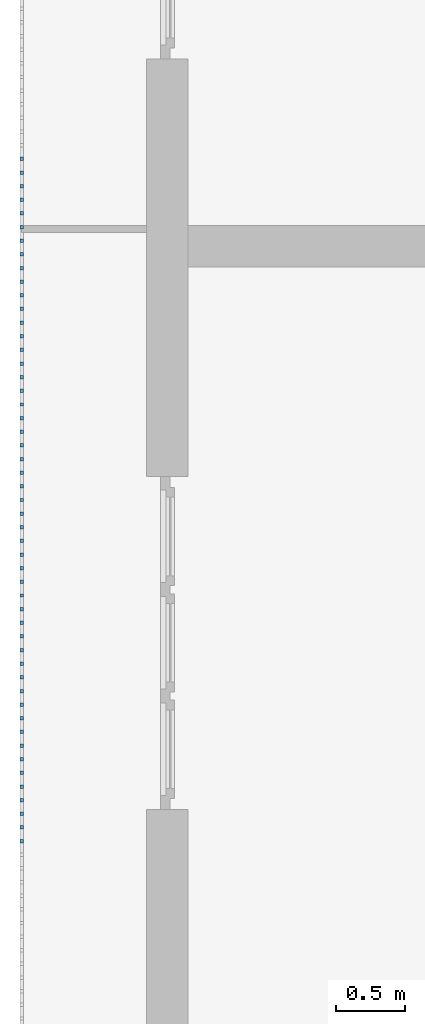
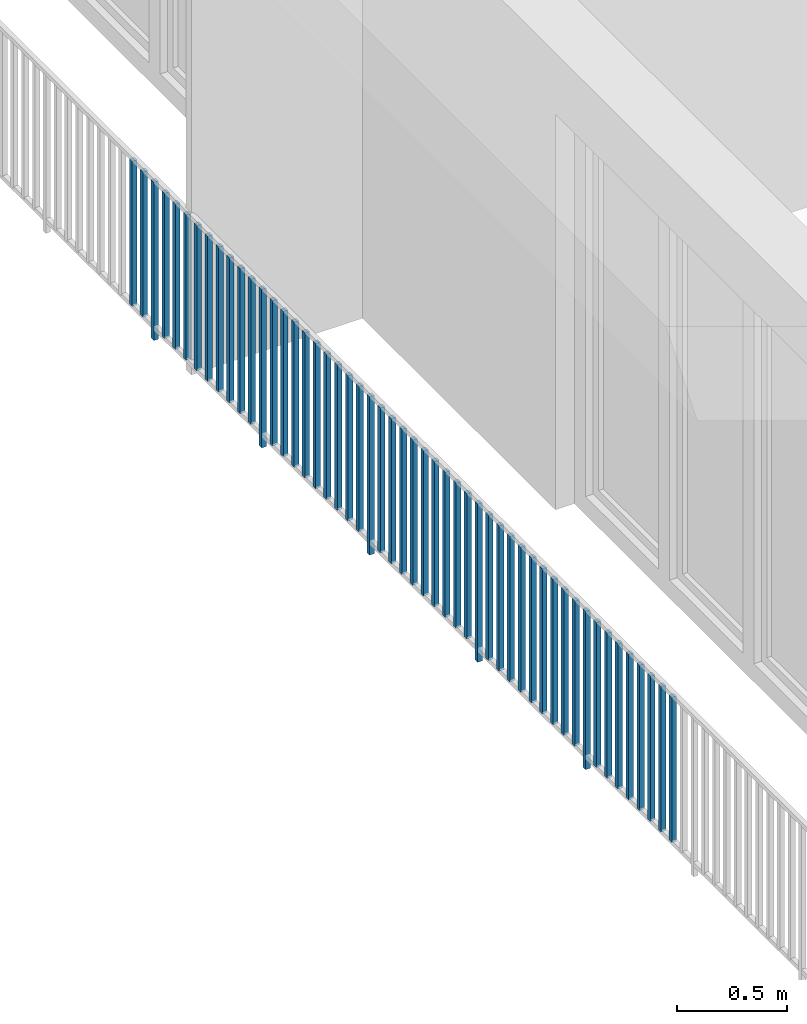
# One storey, part 31 of 48: 51 building element parts, 1 element without a shape of its own.
"""IFC4 building model written with IfcOpenShell, lengths in metres."""

from ifc_helpers import new_model, entity, si_unit, converted_unit, derived_unit, direction, frame, origin_with_axes, place, context, subcontext, project, spatial, polygons, material, type_object, element, aggregate, save


model = new_model("IFC4")

# Units and contexts
model_context = context("Model", 3, precision=1e-05, world=origin_with_axes(), true_north=direction((0.0, 1.0)))
body_context = subcontext(model_context, "Body", "Model", "MODEL_VIEW")
ifc_project = project(units=[si_unit("LENGTHUNIT", "METRE"), si_unit("AREAUNIT", "SQUARE_METRE"), si_unit("VOLUMEUNIT", "CUBIC_METRE"), converted_unit("PLANEANGLEUNIT", "DEGREE", entity("IfcPlaneAngleMeasure", 0.0174532925199), si_unit("PLANEANGLEUNIT", "RADIAN"), dimensions=[0, 0, 0, 0, 0, 0, 0]), converted_unit("TIMEUNIT", "Year", entity("IfcTimeMeasure", 31556926.0), si_unit("TIMEUNIT", "SECOND"), dimensions=[0, 0, 1, 0, 0, 0, 0]), si_unit("MASSUNIT", "GRAM", prefix="KILO"), si_unit("THERMODYNAMICTEMPERATUREUNIT", "DEGREE_CELSIUS"), si_unit("LUMINOUSINTENSITYUNIT", "LUMEN"), si_unit("ENERGYUNIT", "JOULE", prefix="MEGA"), derived_unit("THERMALCONDUCTANCEUNIT", [(si_unit("POWERUNIT", "WATT"), 1), (si_unit("LENGTHUNIT", "METRE"), -1), (si_unit("THERMODYNAMICTEMPERATUREUNIT", "KELVIN"), -1)]), derived_unit("SPECIFICHEATCAPACITYUNIT", [(si_unit("ENERGYUNIT", "JOULE"), 1), (si_unit("MASSUNIT", "GRAM", prefix="KILO"), -1), (si_unit("THERMODYNAMICTEMPERATUREUNIT", "KELVIN"), -1)]), derived_unit("MASSDENSITYUNIT", [(si_unit("MASSUNIT", "GRAM", prefix="KILO"), 1), (si_unit("VOLUMEUNIT", "CUBIC_METRE"), -1)])], contexts=[model_context])

# Site, building, storey
site_placement = place(None, origin_with_axes())
site = spatial("IfcSite", under=ifc_project, at=site_placement, CompositionType="ELEMENT")
building_placement = place(site_placement, origin_with_axes())
building = spatial("IfcBuilding", under=site, at=building_placement, CompositionType="ELEMENT")
storey_placement = place(building_placement, frame((0.0, 0.0, 3.4), z_axis=(0.0, 0.0, 1.0), x_axis=(1.0, 0.0, 0.0)))
storey = spatial("IfcBuildingStorey", under=building, at=storey_placement, Name="1. Geschoss", CompositionType="ELEMENT", Elevation=3.4)

# Railing, building element parts
railing_type = type_object("IfcRailingType", PredefinedType="NOTDEFINED")
railing_placement = place(storey_placement, frame((10.2378006196, 9.82118776896, 0.0), z_axis=(0.0, 0.0, 1.0), x_axis=(1.0, 0.0, 0.0)))
railing = element("IfcRailing", 1, at=railing_placement, inside=storey, type_object=railing_type, PredefinedType="NOTDEFINED")
ifc_material = material()
building_element_part_1_placement = place(railing_placement, origin_with_axes())
building_element_part_1 = element("IfcBuildingElementPart", 2, at=building_element_part_1_placement, material=ifc_material, PredefinedType="NOTDEFINED", context=body_context, shape_type="Tessellation", body=[
    polygons([(-22.8925, -7.6825, 0.07), (-22.8675, -7.6825, 0.07), (-22.8675, -7.6825, 0.8775), (-22.8925, -7.6825, 0.8775), (-22.8925, -7.6575, 0.07), (-22.8675, -7.6575, 0.07), (-22.8675, -7.6575, 0.8775), (-22.8925, -7.6575, 0.8775)], [[[1, 2, 3, 4]], [[1, 5, 6, 2]], [[2, 6, 7, 3]], [[4, 3, 7, 8]], [[5, 1, 4, 8]], [[6, 5, 8, 7]]], closed=True),
])
building_element_part_2_placement = place(railing_placement, origin_with_axes())
building_element_part_2 = element("IfcBuildingElementPart", 3, at=building_element_part_2_placement, material=ifc_material, PredefinedType="NOTDEFINED", context=body_context, shape_type="Tessellation", body=[
    polygons([(-22.8925, -7.78083333333, 0.07), (-22.8675, -7.78083333333, 0.07), (-22.8675, -7.78083333333, 0.8775), (-22.8925, -7.78083333333, 0.8775), (-22.8925, -7.75583333333, 0.07), (-22.8675, -7.75583333333, 0.07), (-22.8675, -7.75583333333, 0.8775), (-22.8925, -7.75583333333, 0.8775)], [[[1, 2, 3, 4]], [[1, 5, 6, 2]], [[2, 6, 7, 3]], [[4, 3, 7, 8]], [[5, 1, 4, 8]], [[6, 5, 8, 7]]], closed=True),
])
building_element_part_3_placement = place(railing_placement, origin_with_axes())
building_element_part_3 = element("IfcBuildingElementPart", 4, at=building_element_part_3_placement, material=ifc_material, PredefinedType="NOTDEFINED", context=body_context, shape_type="Tessellation", body=[
    polygons([(-22.8925, -7.87916666667, 0.0), (-22.8675, -7.87916666667, 0.0), (-22.8675, -7.87916666667, 0.88), (-22.8925, -7.87916666667, 0.88), (-22.8925, -7.85416666667, 0.0), (-22.8675, -7.85416666667, 0.0), (-22.8675, -7.85416666667, 0.88), (-22.8925, -7.85416666667, 0.88)], [[[1, 2, 3, 4]], [[1, 5, 6, 2]], [[2, 6, 7, 3]], [[4, 3, 7, 8]], [[5, 1, 4, 8]], [[6, 5, 8, 7]]], closed=True),
])
building_element_part_4_placement = place(railing_placement, origin_with_axes())
building_element_part_4 = element("IfcBuildingElementPart", 5, at=building_element_part_4_placement, material=ifc_material, PredefinedType="NOTDEFINED", context=body_context, shape_type="Tessellation", body=[
    polygons([(-22.8925, -7.9775, 0.07), (-22.8675, -7.9775, 0.07), (-22.8675, -7.9775, 0.8775), (-22.8925, -7.9775, 0.8775), (-22.8925, -7.9525, 0.07), (-22.8675, -7.9525, 0.07), (-22.8675, -7.9525, 0.8775), (-22.8925, -7.9525, 0.8775)], [[[1, 2, 3, 4]], [[1, 5, 6, 2]], [[2, 6, 7, 3]], [[4, 3, 7, 8]], [[5, 1, 4, 8]], [[6, 5, 8, 7]]], closed=True),
])
building_element_part_5_placement = place(railing_placement, origin_with_axes())
building_element_part_5 = element("IfcBuildingElementPart", 6, at=building_element_part_5_placement, material=ifc_material, PredefinedType="NOTDEFINED", context=body_context, shape_type="Tessellation", body=[
    polygons([(-22.8925, -8.07583333333, 0.07), (-22.8675, -8.07583333333, 0.07), (-22.8675, -8.07583333333, 0.8775), (-22.8925, -8.07583333333, 0.8775), (-22.8925, -8.05083333333, 0.07), (-22.8675, -8.05083333333, 0.07), (-22.8675, -8.05083333333, 0.8775), (-22.8925, -8.05083333333, 0.8775)], [[[1, 2, 3, 4]], [[1, 5, 6, 2]], [[2, 6, 7, 3]], [[4, 3, 7, 8]], [[5, 1, 4, 8]], [[6, 5, 8, 7]]], closed=True),
])
building_element_part_6_placement = place(railing_placement, origin_with_axes())
building_element_part_6 = element("IfcBuildingElementPart", 7, at=building_element_part_6_placement, material=ifc_material, PredefinedType="NOTDEFINED", context=body_context, shape_type="Tessellation", body=[
    polygons([(-22.8925, -8.17416666667, 0.07), (-22.8675, -8.17416666667, 0.07), (-22.8675, -8.17416666667, 0.8775), (-22.8925, -8.17416666667, 0.8775), (-22.8925, -8.14916666667, 0.07), (-22.8675, -8.14916666667, 0.07), (-22.8675, -8.14916666667, 0.8775), (-22.8925, -8.14916666667, 0.8775)], [[[1, 2, 3, 4]], [[1, 5, 6, 2]], [[2, 6, 7, 3]], [[4, 3, 7, 8]], [[5, 1, 4, 8]], [[6, 5, 8, 7]]], closed=True),
])
building_element_part_7_placement = place(railing_placement, origin_with_axes())
building_element_part_7 = element("IfcBuildingElementPart", 8, at=building_element_part_7_placement, material=ifc_material, PredefinedType="NOTDEFINED", context=body_context, shape_type="Tessellation", body=[
    polygons([(-22.8925, -8.2725, 0.07), (-22.8675, -8.2725, 0.07), (-22.8675, -8.2725, 0.8775), (-22.8925, -8.2725, 0.8775), (-22.8925, -8.2475, 0.07), (-22.8675, -8.2475, 0.07), (-22.8675, -8.2475, 0.8775), (-22.8925, -8.2475, 0.8775)], [[[1, 2, 3, 4]], [[1, 5, 6, 2]], [[2, 6, 7, 3]], [[4, 3, 7, 8]], [[5, 1, 4, 8]], [[6, 5, 8, 7]]], closed=True),
])
building_element_part_8_placement = place(railing_placement, origin_with_axes())
building_element_part_8 = element("IfcBuildingElementPart", 9, at=building_element_part_8_placement, material=ifc_material, PredefinedType="NOTDEFINED", context=body_context, shape_type="Tessellation", body=[
    polygons([(-22.8925, -8.37083333333, 0.07), (-22.8675, -8.37083333333, 0.07), (-22.8675, -8.37083333333, 0.8775), (-22.8925, -8.37083333333, 0.8775), (-22.8925, -8.34583333333, 0.07), (-22.8675, -8.34583333333, 0.07), (-22.8675, -8.34583333333, 0.8775), (-22.8925, -8.34583333333, 0.8775)], [[[1, 2, 3, 4]], [[1, 5, 6, 2]], [[2, 6, 7, 3]], [[4, 3, 7, 8]], [[5, 1, 4, 8]], [[6, 5, 8, 7]]], closed=True),
])
building_element_part_9_placement = place(railing_placement, origin_with_axes())
building_element_part_9 = element("IfcBuildingElementPart", 10, at=building_element_part_9_placement, material=ifc_material, PredefinedType="NOTDEFINED", context=body_context, shape_type="Tessellation", body=[
    polygons([(-22.8925, -8.46916666667, 0.07), (-22.8675, -8.46916666667, 0.07), (-22.8675, -8.46916666667, 0.8775), (-22.8925, -8.46916666667, 0.8775), (-22.8925, -8.44416666667, 0.07), (-22.8675, -8.44416666667, 0.07), (-22.8675, -8.44416666667, 0.8775), (-22.8925, -8.44416666667, 0.8775)], [[[1, 2, 3, 4]], [[1, 5, 6, 2]], [[2, 6, 7, 3]], [[4, 3, 7, 8]], [[5, 1, 4, 8]], [[6, 5, 8, 7]]], closed=True),
])
building_element_part_10_placement = place(railing_placement, origin_with_axes())
building_element_part_10 = element("IfcBuildingElementPart", 11, at=building_element_part_10_placement, material=ifc_material, PredefinedType="NOTDEFINED", context=body_context, shape_type="Tessellation", body=[
    polygons([(-22.8925, -8.5675, 0.07), (-22.8675, -8.5675, 0.07), (-22.8675, -8.5675, 0.8775), (-22.8925, -8.5675, 0.8775), (-22.8925, -8.5425, 0.07), (-22.8675, -8.5425, 0.07), (-22.8675, -8.5425, 0.8775), (-22.8925, -8.5425, 0.8775)], [[[1, 2, 3, 4]], [[1, 5, 6, 2]], [[2, 6, 7, 3]], [[4, 3, 7, 8]], [[5, 1, 4, 8]], [[6, 5, 8, 7]]], closed=True),
])
building_element_part_11_placement = place(railing_placement, origin_with_axes())
building_element_part_11 = element("IfcBuildingElementPart", 12, at=building_element_part_11_placement, material=ifc_material, PredefinedType="NOTDEFINED", context=body_context, shape_type="Tessellation", body=[
    polygons([(-22.8925, -8.66583333333, 0.07), (-22.8675, -8.66583333333, 0.07), (-22.8675, -8.66583333333, 0.8775), (-22.8925, -8.66583333333, 0.8775), (-22.8925, -8.64083333333, 0.07), (-22.8675, -8.64083333333, 0.07), (-22.8675, -8.64083333333, 0.8775), (-22.8925, -8.64083333333, 0.8775)], [[[1, 2, 3, 4]], [[1, 5, 6, 2]], [[2, 6, 7, 3]], [[4, 3, 7, 8]], [[5, 1, 4, 8]], [[6, 5, 8, 7]]], closed=True),
])
building_element_part_12_placement = place(railing_placement, origin_with_axes())
building_element_part_12 = element("IfcBuildingElementPart", 13, at=building_element_part_12_placement, material=ifc_material, PredefinedType="NOTDEFINED", context=body_context, shape_type="Tessellation", body=[
    polygons([(-22.8925, -8.76416666667, 0.07), (-22.8675, -8.76416666667, 0.07), (-22.8675, -8.76416666667, 0.8775), (-22.8925, -8.76416666667, 0.8775), (-22.8925, -8.73916666667, 0.07), (-22.8675, -8.73916666667, 0.07), (-22.8675, -8.73916666667, 0.8775), (-22.8925, -8.73916666667, 0.8775)], [[[1, 2, 3, 4]], [[1, 5, 6, 2]], [[2, 6, 7, 3]], [[4, 3, 7, 8]], [[5, 1, 4, 8]], [[6, 5, 8, 7]]], closed=True),
])
building_element_part_13_placement = place(railing_placement, origin_with_axes())
building_element_part_13 = element("IfcBuildingElementPart", 14, at=building_element_part_13_placement, material=ifc_material, PredefinedType="NOTDEFINED", context=body_context, shape_type="Tessellation", body=[
    polygons([(-22.8925, -8.8625, 0.0), (-22.8675, -8.8625, 0.0), (-22.8675, -8.8625, 0.88), (-22.8925, -8.8625, 0.88), (-22.8925, -8.8375, 0.0), (-22.8675, -8.8375, 0.0), (-22.8675, -8.8375, 0.88), (-22.8925, -8.8375, 0.88)], [[[1, 2, 3, 4]], [[1, 5, 6, 2]], [[2, 6, 7, 3]], [[4, 3, 7, 8]], [[5, 1, 4, 8]], [[6, 5, 8, 7]]], closed=True),
])
building_element_part_14_placement = place(railing_placement, origin_with_axes())
building_element_part_14 = element("IfcBuildingElementPart", 15, at=building_element_part_14_placement, material=ifc_material, PredefinedType="NOTDEFINED", context=body_context, shape_type="Tessellation", body=[
    polygons([(-22.8925, -8.96083333333, 0.07), (-22.8675, -8.96083333333, 0.07), (-22.8675, -8.96083333333, 0.8775), (-22.8925, -8.96083333333, 0.8775), (-22.8925, -8.93583333333, 0.07), (-22.8675, -8.93583333333, 0.07), (-22.8675, -8.93583333333, 0.8775), (-22.8925, -8.93583333333, 0.8775)], [[[1, 2, 3, 4]], [[1, 5, 6, 2]], [[2, 6, 7, 3]], [[4, 3, 7, 8]], [[5, 1, 4, 8]], [[6, 5, 8, 7]]], closed=True),
])
building_element_part_15_placement = place(railing_placement, origin_with_axes())
building_element_part_15 = element("IfcBuildingElementPart", 16, at=building_element_part_15_placement, material=ifc_material, PredefinedType="NOTDEFINED", context=body_context, shape_type="Tessellation", body=[
    polygons([(-22.8925, -9.05916666667, 0.07), (-22.8675, -9.05916666667, 0.07), (-22.8675, -9.05916666667, 0.8775), (-22.8925, -9.05916666667, 0.8775), (-22.8925, -9.03416666667, 0.07), (-22.8675, -9.03416666667, 0.07), (-22.8675, -9.03416666667, 0.8775), (-22.8925, -9.03416666667, 0.8775)], [[[1, 2, 3, 4]], [[1, 5, 6, 2]], [[2, 6, 7, 3]], [[4, 3, 7, 8]], [[5, 1, 4, 8]], [[6, 5, 8, 7]]], closed=True),
])
building_element_part_16_placement = place(railing_placement, origin_with_axes())
building_element_part_16 = element("IfcBuildingElementPart", 17, at=building_element_part_16_placement, material=ifc_material, PredefinedType="NOTDEFINED", context=body_context, shape_type="Tessellation", body=[
    polygons([(-22.8925, -9.1575, 0.07), (-22.8675, -9.1575, 0.07), (-22.8675, -9.1575, 0.8775), (-22.8925, -9.1575, 0.8775), (-22.8925, -9.1325, 0.07), (-22.8675, -9.1325, 0.07), (-22.8675, -9.1325, 0.8775), (-22.8925, -9.1325, 0.8775)], [[[1, 2, 3, 4]], [[1, 5, 6, 2]], [[2, 6, 7, 3]], [[4, 3, 7, 8]], [[5, 1, 4, 8]], [[6, 5, 8, 7]]], closed=True),
])
building_element_part_17_placement = place(railing_placement, origin_with_axes())
building_element_part_17 = element("IfcBuildingElementPart", 18, at=building_element_part_17_placement, material=ifc_material, PredefinedType="NOTDEFINED", context=body_context, shape_type="Tessellation", body=[
    polygons([(-22.8925, -9.25583333333, 0.07), (-22.8675, -9.25583333333, 0.07), (-22.8675, -9.25583333333, 0.8775), (-22.8925, -9.25583333333, 0.8775), (-22.8925, -9.23083333333, 0.07), (-22.8675, -9.23083333333, 0.07), (-22.8675, -9.23083333333, 0.8775), (-22.8925, -9.23083333333, 0.8775)], [[[1, 2, 3, 4]], [[1, 5, 6, 2]], [[2, 6, 7, 3]], [[4, 3, 7, 8]], [[5, 1, 4, 8]], [[6, 5, 8, 7]]], closed=True),
])
building_element_part_18_placement = place(railing_placement, origin_with_axes())
building_element_part_18 = element("IfcBuildingElementPart", 19, at=building_element_part_18_placement, material=ifc_material, PredefinedType="NOTDEFINED", context=body_context, shape_type="Tessellation", body=[
    polygons([(-22.8925, -9.35416666667, 0.07), (-22.8675, -9.35416666667, 0.07), (-22.8675, -9.35416666667, 0.8775), (-22.8925, -9.35416666667, 0.8775), (-22.8925, -9.32916666667, 0.07), (-22.8675, -9.32916666667, 0.07), (-22.8675, -9.32916666667, 0.8775), (-22.8925, -9.32916666667, 0.8775)], [[[1, 2, 3, 4]], [[1, 5, 6, 2]], [[2, 6, 7, 3]], [[4, 3, 7, 8]], [[5, 1, 4, 8]], [[6, 5, 8, 7]]], closed=True),
])
building_element_part_19_placement = place(railing_placement, origin_with_axes())
building_element_part_19 = element("IfcBuildingElementPart", 20, at=building_element_part_19_placement, material=ifc_material, PredefinedType="NOTDEFINED", context=body_context, shape_type="Tessellation", body=[
    polygons([(-22.8925, -9.4525, 0.07), (-22.8675, -9.4525, 0.07), (-22.8675, -9.4525, 0.8775), (-22.8925, -9.4525, 0.8775), (-22.8925, -9.4275, 0.07), (-22.8675, -9.4275, 0.07), (-22.8675, -9.4275, 0.8775), (-22.8925, -9.4275, 0.8775)], [[[1, 2, 3, 4]], [[1, 5, 6, 2]], [[2, 6, 7, 3]], [[4, 3, 7, 8]], [[5, 1, 4, 8]], [[6, 5, 8, 7]]], closed=True),
])
building_element_part_20_placement = place(railing_placement, origin_with_axes())
building_element_part_20 = element("IfcBuildingElementPart", 21, at=building_element_part_20_placement, material=ifc_material, PredefinedType="NOTDEFINED", context=body_context, shape_type="Tessellation", body=[
    polygons([(-22.8925, -9.55083333333, 0.07), (-22.8675, -9.55083333333, 0.07), (-22.8675, -9.55083333333, 0.8775), (-22.8925, -9.55083333333, 0.8775), (-22.8925, -9.52583333333, 0.07), (-22.8675, -9.52583333333, 0.07), (-22.8675, -9.52583333333, 0.8775), (-22.8925, -9.52583333333, 0.8775)], [[[1, 2, 3, 4]], [[1, 5, 6, 2]], [[2, 6, 7, 3]], [[4, 3, 7, 8]], [[5, 1, 4, 8]], [[6, 5, 8, 7]]], closed=True),
])
building_element_part_21_placement = place(railing_placement, origin_with_axes())
building_element_part_21 = element("IfcBuildingElementPart", 22, at=building_element_part_21_placement, material=ifc_material, PredefinedType="NOTDEFINED", context=body_context, shape_type="Tessellation", body=[
    polygons([(-22.8925, -9.64916666667, 0.07), (-22.8675, -9.64916666667, 0.07), (-22.8675, -9.64916666667, 0.8775), (-22.8925, -9.64916666667, 0.8775), (-22.8925, -9.62416666667, 0.07), (-22.8675, -9.62416666667, 0.07), (-22.8675, -9.62416666667, 0.8775), (-22.8925, -9.62416666667, 0.8775)], [[[1, 2, 3, 4]], [[1, 5, 6, 2]], [[2, 6, 7, 3]], [[4, 3, 7, 8]], [[5, 1, 4, 8]], [[6, 5, 8, 7]]], closed=True),
])
building_element_part_22_placement = place(railing_placement, origin_with_axes())
building_element_part_22 = element("IfcBuildingElementPart", 23, at=building_element_part_22_placement, material=ifc_material, PredefinedType="NOTDEFINED", context=body_context, shape_type="Tessellation", body=[
    polygons([(-22.8925, -9.7475, 0.07), (-22.8675, -9.7475, 0.07), (-22.8675, -9.7475, 0.8775), (-22.8925, -9.7475, 0.8775), (-22.8925, -9.7225, 0.07), (-22.8675, -9.7225, 0.07), (-22.8675, -9.7225, 0.8775), (-22.8925, -9.7225, 0.8775)], [[[1, 2, 3, 4]], [[1, 5, 6, 2]], [[2, 6, 7, 3]], [[4, 3, 7, 8]], [[5, 1, 4, 8]], [[6, 5, 8, 7]]], closed=True),
])
building_element_part_23_placement = place(railing_placement, origin_with_axes())
building_element_part_23 = element("IfcBuildingElementPart", 24, at=building_element_part_23_placement, material=ifc_material, PredefinedType="NOTDEFINED", context=body_context, shape_type="Tessellation", body=[
    polygons([(-22.8925, -9.84583333333, 0.0), (-22.8675, -9.84583333333, 0.0), (-22.8675, -9.84583333333, 0.88), (-22.8925, -9.84583333333, 0.88), (-22.8925, -9.82083333333, 0.0), (-22.8675, -9.82083333333, 0.0), (-22.8675, -9.82083333333, 0.88), (-22.8925, -9.82083333333, 0.88)], [[[1, 2, 3, 4]], [[1, 5, 6, 2]], [[2, 6, 7, 3]], [[4, 3, 7, 8]], [[5, 1, 4, 8]], [[6, 5, 8, 7]]], closed=True),
])
building_element_part_24_placement = place(railing_placement, origin_with_axes())
building_element_part_24 = element("IfcBuildingElementPart", 25, at=building_element_part_24_placement, material=ifc_material, PredefinedType="NOTDEFINED", context=body_context, shape_type="Tessellation", body=[
    polygons([(-22.8925, -9.94416666667, 0.07), (-22.8675, -9.94416666667, 0.07), (-22.8675, -9.94416666667, 0.8775), (-22.8925, -9.94416666667, 0.8775), (-22.8925, -9.91916666667, 0.07), (-22.8675, -9.91916666667, 0.07), (-22.8675, -9.91916666667, 0.8775), (-22.8925, -9.91916666667, 0.8775)], [[[1, 2, 3, 4]], [[1, 5, 6, 2]], [[2, 6, 7, 3]], [[4, 3, 7, 8]], [[5, 1, 4, 8]], [[6, 5, 8, 7]]], closed=True),
])
building_element_part_25_placement = place(railing_placement, origin_with_axes())
building_element_part_25 = element("IfcBuildingElementPart", 26, at=building_element_part_25_placement, material=ifc_material, PredefinedType="NOTDEFINED", context=body_context, shape_type="Tessellation", body=[
    polygons([(-22.8925, -10.0425, 0.07), (-22.8675, -10.0425, 0.07), (-22.8675, -10.0425, 0.8775), (-22.8925, -10.0425, 0.8775), (-22.8925, -10.0175, 0.07), (-22.8675, -10.0175, 0.07), (-22.8675, -10.0175, 0.8775), (-22.8925, -10.0175, 0.8775)], [[[1, 2, 3, 4]], [[1, 5, 6, 2]], [[2, 6, 7, 3]], [[4, 3, 7, 8]], [[5, 1, 4, 8]], [[6, 5, 8, 7]]], closed=True),
])
building_element_part_26_placement = place(railing_placement, origin_with_axes())
building_element_part_26 = element("IfcBuildingElementPart", 27, at=building_element_part_26_placement, material=ifc_material, PredefinedType="NOTDEFINED", context=body_context, shape_type="Tessellation", body=[
    polygons([(-22.8925, -10.1408333333, 0.07), (-22.8675, -10.1408333333, 0.07), (-22.8675, -10.1408333333, 0.8775), (-22.8925, -10.1408333333, 0.8775), (-22.8925, -10.1158333333, 0.07), (-22.8675, -10.1158333333, 0.07), (-22.8675, -10.1158333333, 0.8775), (-22.8925, -10.1158333333, 0.8775)], [[[1, 2, 3, 4]], [[1, 5, 6, 2]], [[2, 6, 7, 3]], [[4, 3, 7, 8]], [[5, 1, 4, 8]], [[6, 5, 8, 7]]], closed=True),
])
building_element_part_27_placement = place(railing_placement, origin_with_axes())
building_element_part_27 = element("IfcBuildingElementPart", 28, at=building_element_part_27_placement, material=ifc_material, PredefinedType="NOTDEFINED", context=body_context, shape_type="Tessellation", body=[
    polygons([(-22.8925, -10.2391666667, 0.07), (-22.8675, -10.2391666667, 0.07), (-22.8675, -10.2391666667, 0.8775), (-22.8925, -10.2391666667, 0.8775), (-22.8925, -10.2141666667, 0.07), (-22.8675, -10.2141666667, 0.07), (-22.8675, -10.2141666667, 0.8775), (-22.8925, -10.2141666667, 0.8775)], [[[1, 2, 3, 4]], [[1, 5, 6, 2]], [[2, 6, 7, 3]], [[4, 3, 7, 8]], [[5, 1, 4, 8]], [[6, 5, 8, 7]]], closed=True),
])
building_element_part_28_placement = place(railing_placement, origin_with_axes())
building_element_part_28 = element("IfcBuildingElementPart", 29, at=building_element_part_28_placement, material=ifc_material, PredefinedType="NOTDEFINED", context=body_context, shape_type="Tessellation", body=[
    polygons([(-22.8925, -10.3375, 0.07), (-22.8675, -10.3375, 0.07), (-22.8675, -10.3375, 0.8775), (-22.8925, -10.3375, 0.8775), (-22.8925, -10.3125, 0.07), (-22.8675, -10.3125, 0.07), (-22.8675, -10.3125, 0.8775), (-22.8925, -10.3125, 0.8775)], [[[1, 2, 3, 4]], [[1, 5, 6, 2]], [[2, 6, 7, 3]], [[4, 3, 7, 8]], [[5, 1, 4, 8]], [[6, 5, 8, 7]]], closed=True),
])
building_element_part_29_placement = place(railing_placement, origin_with_axes())
building_element_part_29 = element("IfcBuildingElementPart", 30, at=building_element_part_29_placement, material=ifc_material, PredefinedType="NOTDEFINED", context=body_context, shape_type="Tessellation", body=[
    polygons([(-22.8925, -10.4358333333, 0.07), (-22.8675, -10.4358333333, 0.07), (-22.8675, -10.4358333333, 0.8775), (-22.8925, -10.4358333333, 0.8775), (-22.8925, -10.4108333333, 0.07), (-22.8675, -10.4108333333, 0.07), (-22.8675, -10.4108333333, 0.8775), (-22.8925, -10.4108333333, 0.8775)], [[[1, 2, 3, 4]], [[1, 5, 6, 2]], [[2, 6, 7, 3]], [[4, 3, 7, 8]], [[5, 1, 4, 8]], [[6, 5, 8, 7]]], closed=True),
])
building_element_part_30_placement = place(railing_placement, origin_with_axes())
building_element_part_30 = element("IfcBuildingElementPart", 31, at=building_element_part_30_placement, material=ifc_material, PredefinedType="NOTDEFINED", context=body_context, shape_type="Tessellation", body=[
    polygons([(-22.8925, -10.5341666667, 0.07), (-22.8675, -10.5341666667, 0.07), (-22.8675, -10.5341666667, 0.8775), (-22.8925, -10.5341666667, 0.8775), (-22.8925, -10.5091666667, 0.07), (-22.8675, -10.5091666667, 0.07), (-22.8675, -10.5091666667, 0.8775), (-22.8925, -10.5091666667, 0.8775)], [[[1, 2, 3, 4]], [[1, 5, 6, 2]], [[2, 6, 7, 3]], [[4, 3, 7, 8]], [[5, 1, 4, 8]], [[6, 5, 8, 7]]], closed=True),
])
building_element_part_31_placement = place(railing_placement, origin_with_axes())
building_element_part_31 = element("IfcBuildingElementPart", 32, at=building_element_part_31_placement, material=ifc_material, PredefinedType="NOTDEFINED", context=body_context, shape_type="Tessellation", body=[
    polygons([(-22.8925, -10.6325, 0.07), (-22.8675, -10.6325, 0.07), (-22.8675, -10.6325, 0.8775), (-22.8925, -10.6325, 0.8775), (-22.8925, -10.6075, 0.07), (-22.8675, -10.6075, 0.07), (-22.8675, -10.6075, 0.8775), (-22.8925, -10.6075, 0.8775)], [[[1, 2, 3, 4]], [[1, 5, 6, 2]], [[2, 6, 7, 3]], [[4, 3, 7, 8]], [[5, 1, 4, 8]], [[6, 5, 8, 7]]], closed=True),
])
building_element_part_32_placement = place(railing_placement, origin_with_axes())
building_element_part_32 = element("IfcBuildingElementPart", 33, at=building_element_part_32_placement, material=ifc_material, PredefinedType="NOTDEFINED", context=body_context, shape_type="Tessellation", body=[
    polygons([(-22.8925, -10.7308333333, 0.07), (-22.8675, -10.7308333333, 0.07), (-22.8675, -10.7308333333, 0.8775), (-22.8925, -10.7308333333, 0.8775), (-22.8925, -10.7058333333, 0.07), (-22.8675, -10.7058333333, 0.07), (-22.8675, -10.7058333333, 0.8775), (-22.8925, -10.7058333333, 0.8775)], [[[1, 2, 3, 4]], [[1, 5, 6, 2]], [[2, 6, 7, 3]], [[4, 3, 7, 8]], [[5, 1, 4, 8]], [[6, 5, 8, 7]]], closed=True),
])
building_element_part_33_placement = place(railing_placement, origin_with_axes())
building_element_part_33 = element("IfcBuildingElementPart", 34, at=building_element_part_33_placement, material=ifc_material, PredefinedType="NOTDEFINED", context=body_context, shape_type="Tessellation", body=[
    polygons([(-22.8925, -10.8291666667, 0.0), (-22.8675, -10.8291666667, 0.0), (-22.8675, -10.8291666667, 0.88), (-22.8925, -10.8291666667, 0.88), (-22.8925, -10.8041666667, 0.0), (-22.8675, -10.8041666667, 0.0), (-22.8675, -10.8041666667, 0.88), (-22.8925, -10.8041666667, 0.88)], [[[1, 2, 3, 4]], [[1, 5, 6, 2]], [[2, 6, 7, 3]], [[4, 3, 7, 8]], [[5, 1, 4, 8]], [[6, 5, 8, 7]]], closed=True),
])
building_element_part_34_placement = place(railing_placement, origin_with_axes())
building_element_part_34 = element("IfcBuildingElementPart", 35, at=building_element_part_34_placement, material=ifc_material, PredefinedType="NOTDEFINED", context=body_context, shape_type="Tessellation", body=[
    polygons([(-22.8925, -10.9275, 0.07), (-22.8675, -10.9275, 0.07), (-22.8675, -10.9275, 0.8775), (-22.8925, -10.9275, 0.8775), (-22.8925, -10.9025, 0.07), (-22.8675, -10.9025, 0.07), (-22.8675, -10.9025, 0.8775), (-22.8925, -10.9025, 0.8775)], [[[1, 2, 3, 4]], [[1, 5, 6, 2]], [[2, 6, 7, 3]], [[4, 3, 7, 8]], [[5, 1, 4, 8]], [[6, 5, 8, 7]]], closed=True),
])
building_element_part_35_placement = place(railing_placement, origin_with_axes())
building_element_part_35 = element("IfcBuildingElementPart", 36, at=building_element_part_35_placement, material=ifc_material, PredefinedType="NOTDEFINED", context=body_context, shape_type="Tessellation", body=[
    polygons([(-22.8925, -11.0258333333, 0.07), (-22.8675, -11.0258333333, 0.07), (-22.8675, -11.0258333333, 0.8775), (-22.8925, -11.0258333333, 0.8775), (-22.8925, -11.0008333333, 0.07), (-22.8675, -11.0008333333, 0.07), (-22.8675, -11.0008333333, 0.8775), (-22.8925, -11.0008333333, 0.8775)], [[[1, 2, 3, 4]], [[1, 5, 6, 2]], [[2, 6, 7, 3]], [[4, 3, 7, 8]], [[5, 1, 4, 8]], [[6, 5, 8, 7]]], closed=True),
])
building_element_part_36_placement = place(railing_placement, origin_with_axes())
building_element_part_36 = element("IfcBuildingElementPart", 37, at=building_element_part_36_placement, material=ifc_material, PredefinedType="NOTDEFINED", context=body_context, shape_type="Tessellation", body=[
    polygons([(-22.8925, -11.1241666667, 0.07), (-22.8675, -11.1241666667, 0.07), (-22.8675, -11.1241666667, 0.8775), (-22.8925, -11.1241666667, 0.8775), (-22.8925, -11.0991666667, 0.07), (-22.8675, -11.0991666667, 0.07), (-22.8675, -11.0991666667, 0.8775), (-22.8925, -11.0991666667, 0.8775)], [[[1, 2, 3, 4]], [[1, 5, 6, 2]], [[2, 6, 7, 3]], [[4, 3, 7, 8]], [[5, 1, 4, 8]], [[6, 5, 8, 7]]], closed=True),
])
building_element_part_37_placement = place(railing_placement, origin_with_axes())
building_element_part_37 = element("IfcBuildingElementPart", 38, at=building_element_part_37_placement, material=ifc_material, PredefinedType="NOTDEFINED", context=body_context, shape_type="Tessellation", body=[
    polygons([(-22.8925, -11.2225, 0.07), (-22.8675, -11.2225, 0.07), (-22.8675, -11.2225, 0.8775), (-22.8925, -11.2225, 0.8775), (-22.8925, -11.1975, 0.07), (-22.8675, -11.1975, 0.07), (-22.8675, -11.1975, 0.8775), (-22.8925, -11.1975, 0.8775)], [[[1, 2, 3, 4]], [[1, 5, 6, 2]], [[2, 6, 7, 3]], [[4, 3, 7, 8]], [[5, 1, 4, 8]], [[6, 5, 8, 7]]], closed=True),
])
building_element_part_38_placement = place(railing_placement, origin_with_axes())
building_element_part_38 = element("IfcBuildingElementPart", 39, at=building_element_part_38_placement, material=ifc_material, PredefinedType="NOTDEFINED", context=body_context, shape_type="Tessellation", body=[
    polygons([(-22.8925, -11.3208333333, 0.07), (-22.8675, -11.3208333333, 0.07), (-22.8675, -11.3208333333, 0.8775), (-22.8925, -11.3208333333, 0.8775), (-22.8925, -11.2958333333, 0.07), (-22.8675, -11.2958333333, 0.07), (-22.8675, -11.2958333333, 0.8775), (-22.8925, -11.2958333333, 0.8775)], [[[1, 2, 3, 4]], [[1, 5, 6, 2]], [[2, 6, 7, 3]], [[4, 3, 7, 8]], [[5, 1, 4, 8]], [[6, 5, 8, 7]]], closed=True),
])
building_element_part_39_placement = place(railing_placement, origin_with_axes())
building_element_part_39 = element("IfcBuildingElementPart", 40, at=building_element_part_39_placement, material=ifc_material, PredefinedType="NOTDEFINED", context=body_context, shape_type="Tessellation", body=[
    polygons([(-22.8925, -11.4191666667, 0.07), (-22.8675, -11.4191666667, 0.07), (-22.8675, -11.4191666667, 0.8775), (-22.8925, -11.4191666667, 0.8775), (-22.8925, -11.3941666667, 0.07), (-22.8675, -11.3941666667, 0.07), (-22.8675, -11.3941666667, 0.8775), (-22.8925, -11.3941666667, 0.8775)], [[[1, 2, 3, 4]], [[1, 5, 6, 2]], [[2, 6, 7, 3]], [[4, 3, 7, 8]], [[5, 1, 4, 8]], [[6, 5, 8, 7]]], closed=True),
])
building_element_part_40_placement = place(railing_placement, origin_with_axes())
building_element_part_40 = element("IfcBuildingElementPart", 41, at=building_element_part_40_placement, material=ifc_material, PredefinedType="NOTDEFINED", context=body_context, shape_type="Tessellation", body=[
    polygons([(-22.8925, -11.5175, 0.07), (-22.8675, -11.5175, 0.07), (-22.8675, -11.5175, 0.8775), (-22.8925, -11.5175, 0.8775), (-22.8925, -11.4925, 0.07), (-22.8675, -11.4925, 0.07), (-22.8675, -11.4925, 0.8775), (-22.8925, -11.4925, 0.8775)], [[[1, 2, 3, 4]], [[1, 5, 6, 2]], [[2, 6, 7, 3]], [[4, 3, 7, 8]], [[5, 1, 4, 8]], [[6, 5, 8, 7]]], closed=True),
])
building_element_part_41_placement = place(railing_placement, origin_with_axes())
building_element_part_41 = element("IfcBuildingElementPart", 42, at=building_element_part_41_placement, material=ifc_material, PredefinedType="NOTDEFINED", context=body_context, shape_type="Tessellation", body=[
    polygons([(-22.8925, -11.6158333333, 0.07), (-22.8675, -11.6158333333, 0.07), (-22.8675, -11.6158333333, 0.8775), (-22.8925, -11.6158333333, 0.8775), (-22.8925, -11.5908333333, 0.07), (-22.8675, -11.5908333333, 0.07), (-22.8675, -11.5908333333, 0.8775), (-22.8925, -11.5908333333, 0.8775)], [[[1, 2, 3, 4]], [[1, 5, 6, 2]], [[2, 6, 7, 3]], [[4, 3, 7, 8]], [[5, 1, 4, 8]], [[6, 5, 8, 7]]], closed=True),
])
building_element_part_42_placement = place(railing_placement, origin_with_axes())
building_element_part_42 = element("IfcBuildingElementPart", 43, at=building_element_part_42_placement, material=ifc_material, PredefinedType="NOTDEFINED", context=body_context, shape_type="Tessellation", body=[
    polygons([(-22.8925, -11.7141666667, 0.07), (-22.8675, -11.7141666667, 0.07), (-22.8675, -11.7141666667, 0.8775), (-22.8925, -11.7141666667, 0.8775), (-22.8925, -11.6891666667, 0.07), (-22.8675, -11.6891666667, 0.07), (-22.8675, -11.6891666667, 0.8775), (-22.8925, -11.6891666667, 0.8775)], [[[1, 2, 3, 4]], [[1, 5, 6, 2]], [[2, 6, 7, 3]], [[4, 3, 7, 8]], [[5, 1, 4, 8]], [[6, 5, 8, 7]]], closed=True),
])
building_element_part_43_placement = place(railing_placement, origin_with_axes())
building_element_part_43 = element("IfcBuildingElementPart", 44, at=building_element_part_43_placement, material=ifc_material, PredefinedType="NOTDEFINED", context=body_context, shape_type="Tessellation", body=[
    polygons([(-22.8925, -11.8125, 0.0), (-22.8675, -11.8125, 0.0), (-22.8675, -11.8125, 0.88), (-22.8925, -11.8125, 0.88), (-22.8925, -11.7875, 0.0), (-22.8675, -11.7875, 0.0), (-22.8675, -11.7875, 0.88), (-22.8925, -11.7875, 0.88)], [[[1, 2, 3, 4]], [[1, 5, 6, 2]], [[2, 6, 7, 3]], [[4, 3, 7, 8]], [[5, 1, 4, 8]], [[6, 5, 8, 7]]], closed=True),
])
building_element_part_44_placement = place(railing_placement, origin_with_axes())
building_element_part_44 = element("IfcBuildingElementPart", 45, at=building_element_part_44_placement, material=ifc_material, PredefinedType="NOTDEFINED", context=body_context, shape_type="Tessellation", body=[
    polygons([(-22.8925, -11.9108333333, 0.07), (-22.8675, -11.9108333333, 0.07), (-22.8675, -11.9108333333, 0.8775), (-22.8925, -11.9108333333, 0.8775), (-22.8925, -11.8858333333, 0.07), (-22.8675, -11.8858333333, 0.07), (-22.8675, -11.8858333333, 0.8775), (-22.8925, -11.8858333333, 0.8775)], [[[1, 2, 3, 4]], [[1, 5, 6, 2]], [[2, 6, 7, 3]], [[4, 3, 7, 8]], [[5, 1, 4, 8]], [[6, 5, 8, 7]]], closed=True),
])
building_element_part_45_placement = place(railing_placement, origin_with_axes())
building_element_part_45 = element("IfcBuildingElementPart", 46, at=building_element_part_45_placement, material=ifc_material, PredefinedType="NOTDEFINED", context=body_context, shape_type="Tessellation", body=[
    polygons([(-22.8925, -12.0091666667, 0.07), (-22.8675, -12.0091666667, 0.07), (-22.8675, -12.0091666667, 0.8775), (-22.8925, -12.0091666667, 0.8775), (-22.8925, -11.9841666667, 0.07), (-22.8675, -11.9841666667, 0.07), (-22.8675, -11.9841666667, 0.8775), (-22.8925, -11.9841666667, 0.8775)], [[[1, 2, 3, 4]], [[1, 5, 6, 2]], [[2, 6, 7, 3]], [[4, 3, 7, 8]], [[5, 1, 4, 8]], [[6, 5, 8, 7]]], closed=True),
])
building_element_part_46_placement = place(railing_placement, origin_with_axes())
building_element_part_46 = element("IfcBuildingElementPart", 47, at=building_element_part_46_placement, material=ifc_material, PredefinedType="NOTDEFINED", context=body_context, shape_type="Tessellation", body=[
    polygons([(-22.8925, -12.1075, 0.07), (-22.8675, -12.1075, 0.07), (-22.8675, -12.1075, 0.8775), (-22.8925, -12.1075, 0.8775), (-22.8925, -12.0825, 0.07), (-22.8675, -12.0825, 0.07), (-22.8675, -12.0825, 0.8775), (-22.8925, -12.0825, 0.8775)], [[[1, 2, 3, 4]], [[1, 5, 6, 2]], [[2, 6, 7, 3]], [[4, 3, 7, 8]], [[5, 1, 4, 8]], [[6, 5, 8, 7]]], closed=True),
])
building_element_part_47_placement = place(railing_placement, origin_with_axes())
building_element_part_47 = element("IfcBuildingElementPart", 48, at=building_element_part_47_placement, material=ifc_material, PredefinedType="NOTDEFINED", context=body_context, shape_type="Tessellation", body=[
    polygons([(-22.8925, -12.2058333333, 0.07), (-22.8675, -12.2058333333, 0.07), (-22.8675, -12.2058333333, 0.8775), (-22.8925, -12.2058333333, 0.8775), (-22.8925, -12.1808333333, 0.07), (-22.8675, -12.1808333333, 0.07), (-22.8675, -12.1808333333, 0.8775), (-22.8925, -12.1808333333, 0.8775)], [[[1, 2, 3, 4]], [[1, 5, 6, 2]], [[2, 6, 7, 3]], [[4, 3, 7, 8]], [[5, 1, 4, 8]], [[6, 5, 8, 7]]], closed=True),
])
building_element_part_48_placement = place(railing_placement, origin_with_axes())
building_element_part_48 = element("IfcBuildingElementPart", 49, at=building_element_part_48_placement, material=ifc_material, PredefinedType="NOTDEFINED", context=body_context, shape_type="Tessellation", body=[
    polygons([(-22.8925, -12.3041666667, 0.07), (-22.8675, -12.3041666667, 0.07), (-22.8675, -12.3041666667, 0.8775), (-22.8925, -12.3041666667, 0.8775), (-22.8925, -12.2791666667, 0.07), (-22.8675, -12.2791666667, 0.07), (-22.8675, -12.2791666667, 0.8775), (-22.8925, -12.2791666667, 0.8775)], [[[1, 2, 3, 4]], [[1, 5, 6, 2]], [[2, 6, 7, 3]], [[4, 3, 7, 8]], [[5, 1, 4, 8]], [[6, 5, 8, 7]]], closed=True),
])
building_element_part_49_placement = place(railing_placement, origin_with_axes())
building_element_part_49 = element("IfcBuildingElementPart", 50, at=building_element_part_49_placement, material=ifc_material, PredefinedType="NOTDEFINED", context=body_context, shape_type="Tessellation", body=[
    polygons([(-22.8925, -12.4025, 0.07), (-22.8675, -12.4025, 0.07), (-22.8675, -12.4025, 0.8775), (-22.8925, -12.4025, 0.8775), (-22.8925, -12.3775, 0.07), (-22.8675, -12.3775, 0.07), (-22.8675, -12.3775, 0.8775), (-22.8925, -12.3775, 0.8775)], [[[1, 2, 3, 4]], [[1, 5, 6, 2]], [[2, 6, 7, 3]], [[4, 3, 7, 8]], [[5, 1, 4, 8]], [[6, 5, 8, 7]]], closed=True),
])
building_element_part_50_placement = place(railing_placement, origin_with_axes())
building_element_part_50 = element("IfcBuildingElementPart", 51, at=building_element_part_50_placement, material=ifc_material, PredefinedType="NOTDEFINED", context=body_context, shape_type="Tessellation", body=[
    polygons([(-22.8925, -12.5008333333, 0.07), (-22.8675, -12.5008333333, 0.07), (-22.8675, -12.5008333333, 0.8775), (-22.8925, -12.5008333333, 0.8775), (-22.8925, -12.4758333333, 0.07), (-22.8675, -12.4758333333, 0.07), (-22.8675, -12.4758333333, 0.8775), (-22.8925, -12.4758333333, 0.8775)], [[[1, 2, 3, 4]], [[1, 5, 6, 2]], [[2, 6, 7, 3]], [[4, 3, 7, 8]], [[5, 1, 4, 8]], [[6, 5, 8, 7]]], closed=True),
])
building_element_part_51_placement = place(railing_placement, origin_with_axes())
building_element_part_51 = element("IfcBuildingElementPart", 52, at=building_element_part_51_placement, material=ifc_material, PredefinedType="NOTDEFINED", context=body_context, shape_type="Tessellation", body=[
    polygons([(-22.8925, -12.5991666667, 0.07), (-22.8675, -12.5991666667, 0.07), (-22.8675, -12.5991666667, 0.8775), (-22.8925, -12.5991666667, 0.8775), (-22.8925, -12.5741666667, 0.07), (-22.8675, -12.5741666667, 0.07), (-22.8675, -12.5741666667, 0.8775), (-22.8925, -12.5741666667, 0.8775)], [[[1, 2, 3, 4]], [[1, 5, 6, 2]], [[2, 6, 7, 3]], [[4, 3, 7, 8]], [[5, 1, 4, 8]], [[6, 5, 8, 7]]], closed=True),
])
aggregate(railing, [building_element_part_1, building_element_part_2, building_element_part_3, building_element_part_4, building_element_part_5, building_element_part_6, building_element_part_7, building_element_part_8, building_element_part_9, building_element_part_10, building_element_part_11, building_element_part_12, building_element_part_13, building_element_part_14, building_element_part_15, building_element_part_16, building_element_part_17, building_element_part_18, building_element_part_19, building_element_part_20, building_element_part_21, building_element_part_22, building_element_part_23, building_element_part_24, building_element_part_25, building_element_part_26, building_element_part_27, building_element_part_28, building_element_part_29, building_element_part_30, building_element_part_31, building_element_part_32, building_element_part_33, building_element_part_34, building_element_part_35, building_element_part_36, building_element_part_37, building_element_part_38, building_element_part_39, building_element_part_40, building_element_part_41, building_element_part_42, building_element_part_43, building_element_part_44, building_element_part_45, building_element_part_46, building_element_part_47, building_element_part_48, building_element_part_49, building_element_part_50, building_element_part_51])

save(model, "model.ifc")
